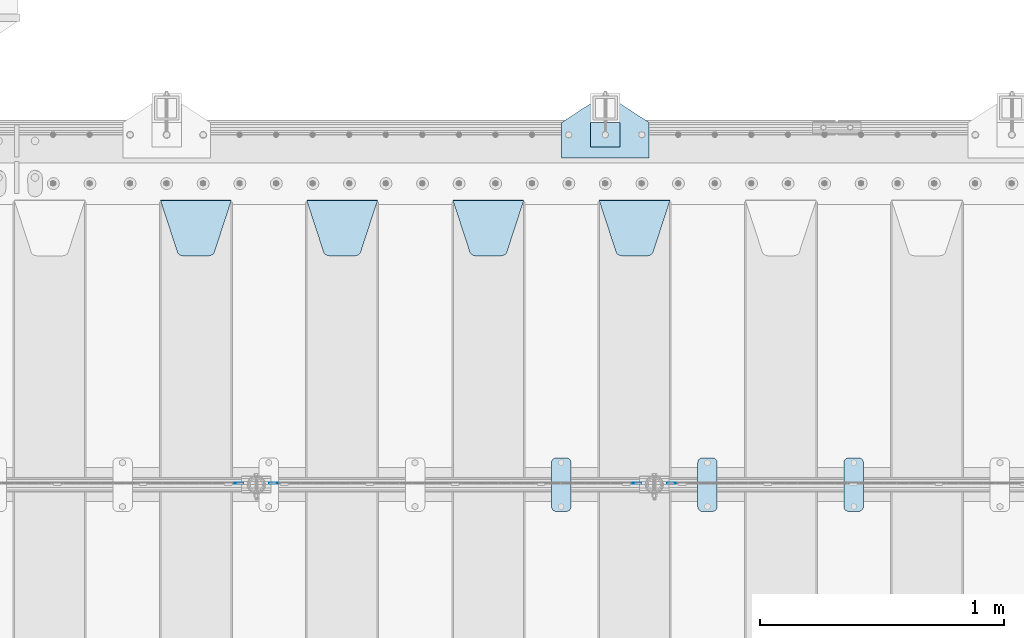
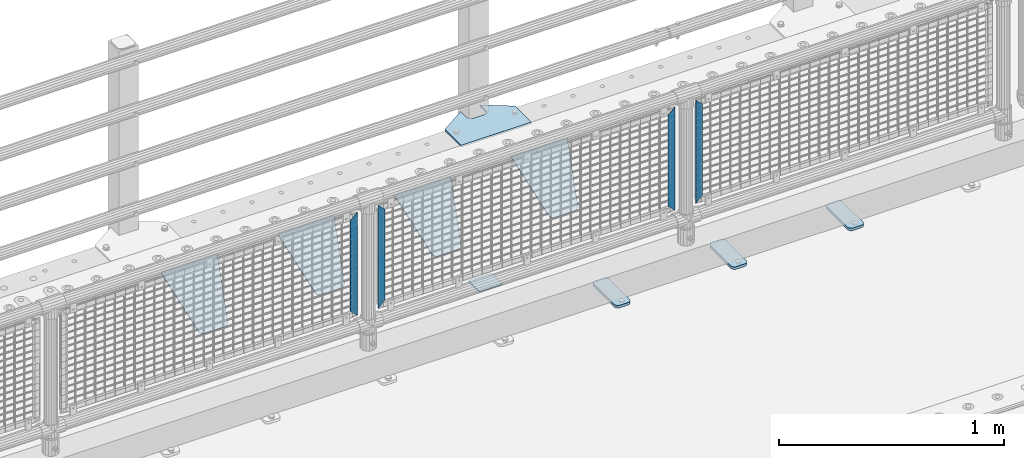
# One storey, part 249 of 270: 13 plates.
"""IFC2X3 building model written with IfcOpenShell, lengths in millimetres."""

from ifc_helpers import new_model, si_unit, frame, origin_with_axes, place, context, subcontext, project, spatial, faceted_brep, material, type_object, element, save


model = new_model("IFC2X3")

# Units and contexts
model_context = context("Model", 3, precision=1e-05, world=origin_with_axes())
body_context = subcontext(model_context, "Body", "Model", "MODEL_VIEW")
ifc_project = project(units=[si_unit("LENGTHUNIT", "METRE", prefix="MILLI"), si_unit("AREAUNIT", "SQUARE_METRE"), si_unit("VOLUMEUNIT", "CUBIC_METRE"), si_unit("MASSUNIT", "GRAM", prefix="KILO"), si_unit("TIMEUNIT", "SECOND"), si_unit("PLANEANGLEUNIT", "RADIAN"), si_unit("SOLIDANGLEUNIT", "STERADIAN"), si_unit("THERMODYNAMICTEMPERATUREUNIT", "DEGREE_CELSIUS"), si_unit("LUMINOUSINTENSITYUNIT", "LUMEN")], contexts=[model_context])

# Site, building, storey
site_placement = place(None, origin_with_axes())
site = spatial("IfcSite", under=ifc_project, at=site_placement, CompositionType="ELEMENT")
building_placement = place(site_placement, origin_with_axes())
building = spatial("IfcBuilding", under=site, at=building_placement, Name="Standard", CompositionType="ELEMENT")
storey_placement = place(building_placement, origin_with_axes())
storey = spatial("IfcBuildingStorey", under=building, at=storey_placement, Name="Undefined", CompositionType="ELEMENT", Elevation=0.0)

# Plates
ifc_material_1 = material(Name="STEEL/S355J2")
plate_type_1 = type_object("IfcPlateType", PredefinedType="NOTDEFINED")
plate_1_placement = place(storey_placement, frame((16570.0, -14995.0, 5.00000000004911), z_axis=(0.0, 1.0, 0.0), x_axis=(1.0, 0.0, 0.0)))
element("IfcPlate", 1, at=plate_1_placement, inside=storey, type_object=plate_type_1, material=ifc_material_1, context=body_context, shape_type="Brep", body=[
    faceted_brep([(0.0, -5.0, 0.0), (2.31396552408114e-06, -5.0, 145.0), (2.31396552408114e-06, 5.0, 145.0), (0.0, 5.0, 0.0), (130.0, -5.0, 230.0), (130.0, 5.0, 230.0), (130.0, -5.0, 180.0), (130.0, 5.0, 180.0), (130.48036798992, -5.0, 175.122741949597), (130.48036798992, 5.0, 175.122741949597), (131.903011687216, -5.0, 170.432914190873), (131.903011687216, 5.0, 170.432914190873), (134.213259692435, -5.0, 166.11074417451), (134.213259692435, 5.0, 166.11074417451), (137.322330470335, -5.0, 162.322330470337), (137.322330470335, 5.0, 162.322330470337), (141.110744174512, -5.0, 159.213259692437), (141.110744174512, 5.0, 159.213259692437), (145.432914190871, -5.0, 156.903011687218), (145.432914190871, 5.0, 156.903011687218), (150.122741949595, -5.0, 155.48036798992), (150.122741949595, 5.0, 155.48036798992), (155.0, -5.0, 155.0), (155.0, 5.0, 155.0), (205.0, -5.0, 155.0), (205.0, 5.0, 155.0), (209.877258050405, -5.0, 155.48036798992), (209.877258050405, 5.0, 155.48036798992), (214.567085809129, -5.0, 156.903011687218), (214.567085809129, 5.0, 156.903011687218), (218.889255825488, -5.0, 159.213259692437), (218.889255825488, 5.0, 159.213259692437), (222.677669529665, -5.0, 162.322330470337), (222.677669529665, 5.0, 162.322330470337), (225.786740307565, -5.0, 166.11074417451), (225.786740307565, 5.0, 166.11074417451), (228.096988312784, -5.0, 170.432914190873), (228.096988312784, 5.0, 170.432914190873), (229.51963201008, -5.0, 175.122741949597), (229.51963201008, 5.0, 175.122741949597), (230.0, -5.0, 180.0), (230.0, 5.0, 180.0), (230.0, -5.0, 230.0), (230.0, 5.0, 230.0), (360.0, -5.0, 145.0), (360.0, 5.0, 145.0), (360.0, -5.0, -7.27595761418343e-12), (360.0, 5.0, -7.27595761418343e-12)], [[[0, 1, 2, 3]], [[1, 4, 5, 2]], [[4, 6, 7, 5]], [[6, 8, 9, 7]], [[8, 10, 11, 9]], [[10, 12, 13, 11]], [[12, 14, 15, 13]], [[14, 16, 17, 15]], [[16, 18, 19, 17]], [[18, 20, 21, 19]], [[20, 22, 23, 21]], [[22, 24, 25, 23]], [[24, 26, 27, 25]], [[26, 28, 29, 27]], [[28, 30, 31, 29]], [[30, 32, 33, 31]], [[32, 34, 35, 33]], [[34, 36, 37, 35]], [[36, 38, 39, 37]], [[38, 40, 41, 39]], [[40, 42, 43, 41]], [[42, 44, 45, 43]], [[44, 46, 47, 45]], [[46, 0, 3, 47]], [[5, 7, 9, 11, 13, 15, 17, 19, 21, 23, 25, 27, 29, 31, 33, 35, 37, 39, 41, 43, 45, 47, 3, 2]], [[46, 44, 42, 40, 38, 36, 34, 32, 30, 28, 26, 24, 22, 20, 18, 16, 14, 12, 10, 8, 6, 4, 1, 0]]]),
])
plate_type_2 = type_object("IfcPlateType", PredefinedType="NOTDEFINED")
plate_2_placement = place(storey_placement, frame((16690.0000000001, -14949.9999999998, -857.500000000002), z_axis=(0.0, 1.0, 0.0), x_axis=(1.0, 0.0, 0.0)))
element("IfcPlate", 2, at=plate_2_placement, inside=storey, type_object=plate_type_2, material=ifc_material_1, context=body_context, shape_type="Brep", body=[
    faceted_brep([(0.0, -2.5, 0.0), (0.0, -2.5, 100.0), (0.0, 2.5, 100.0), (0.0, 2.5, 0.0), (120.0, -2.5, 100.0), (120.0, 2.5, 100.0), (120.0, -2.5, 0.0), (120.0, 2.5, 0.0)], [[[0, 1, 2, 3]], [[1, 4, 5, 2]], [[4, 6, 7, 5]], [[6, 0, 3, 7]], [[5, 7, 3, 2]], [[6, 4, 1, 0]]]),
])
plate_type_3 = type_object("IfcPlateType", PredefinedType="NOTDEFINED")
plate_3_placement = place(storey_placement, frame((17729.0, -16225.5, 21.0199999999977), z_axis=(1.0, 0.0, 0.0), x_axis=(0.0, -1.0, 0.0)))
element("IfcPlate", 3, at=plate_3_placement, inside=storey, type_object=plate_type_3, material=ifc_material_1, context=body_context, shape_type="Brep", body=[
    faceted_brep([(0.0, -7.0, 20.0), (0.0, -7.0, 60.0), (0.0, 7.0, 60.0), (0.0, 7.0, 20.0), (0.384294391937146, -7.0, 63.9018064403208), (0.384294391937146, 7.0, 63.9018064403208), (1.52240934977453, -7.0, 67.6536686473009), (1.52240934977453, 7.0, 67.6536686473009), (3.37060775395003, -7.0, 71.1114046603907), (3.37060775395003, 7.0, 71.1114046603907), (5.8578643762703, -7.0, 74.1421356237297), (5.8578643762703, 7.0, 74.1421356237297), (8.88859533960931, -7.0, 76.62939224605), (8.88859533960931, 7.0, 76.62939224605), (12.3463313526991, -7.0, 78.4775906502255), (12.3463313526991, 7.0, 78.4775906502255), (16.0981935596792, -7.0, 79.6157056080629), (16.0981935596792, 7.0, 79.6157056080629), (20.0, -7.0, 80.0), (20.0, 7.0, 80.0), (200.0, -7.0, 80.0), (200.0, 7.0, 80.0), (203.901806440321, -7.0, 79.6157056080629), (203.901806440321, 7.0, 79.6157056080629), (207.653668647301, -7.0, 78.4775906502255), (207.653668647301, 7.0, 78.4775906502255), (211.111404660391, -7.0, 76.62939224605), (211.111404660391, 7.0, 76.62939224605), (214.142135623733, -7.0, 74.1421356237297), (214.142135623733, 7.0, 74.1421356237297), (216.629392246054, -7.0, 71.1114046603907), (216.629392246054, 7.0, 71.1114046603907), (218.477590650225, -7.0, 67.6536686473009), (218.477590650225, 7.0, 67.6536686473009), (219.615705608063, -7.0, 63.9018064403208), (219.615705608063, 7.0, 63.9018064403208), (220.0, -7.0, 60.0), (220.0, 7.0, 60.0), (220.0, -7.0, 20.0), (220.0, 7.0, 20.0), (219.615705608063, -7.0, 16.0981935596792), (219.615705608063, 7.0, 16.0981935596792), (218.477590650225, -7.0, 12.3463313526991), (218.477590650225, 7.0, 12.3463313526991), (216.629392246054, -7.0, 8.88859533960931), (216.629392246054, 7.0, 8.88859533960931), (214.142135623733, -7.0, 5.8578643762703), (214.142135623733, 7.0, 5.8578643762703), (211.111404660391, -7.0, 3.37060775395003), (211.111404660391, 7.0, 3.37060775395003), (207.653668647301, -7.0, 1.52240934977453), (207.653668647301, 7.0, 1.52240934977453), (203.901806440321, -7.0, 0.384294391937146), (203.901806440321, 7.0, 0.384294391937146), (200.0, -7.0, 0.0), (200.0, 7.0, 0.0), (20.0, -7.0, 0.0), (20.0, 7.0, 0.0), (16.0981935596792, -7.0, 0.384294391937146), (16.0981935596792, 7.0, 0.384294391937146), (12.3463313526991, -7.0, 1.52240934977453), (12.3463313526991, 7.0, 1.52240934977453), (8.88859533960931, -7.0, 3.37060775395003), (8.88859533960931, 7.0, 3.37060775395003), (5.8578643762703, -7.0, 5.8578643762703), (5.8578643762703, 7.0, 5.8578643762703), (3.37060775395003, -7.0, 8.88859533960931), (3.37060775395003, 7.0, 8.88859533960931), (1.52240934977453, -7.0, 12.3463313526991), (1.52240934977453, 7.0, 12.3463313526991), (0.384294391937146, -7.0, 16.0981935596792), (0.384294391937146, 7.0, 16.0981935596792)], [[[0, 1, 2, 3]], [[1, 4, 5, 2]], [[4, 6, 7, 5]], [[6, 8, 9, 7]], [[8, 10, 11, 9]], [[10, 12, 13, 11]], [[12, 14, 15, 13]], [[14, 16, 17, 15]], [[16, 18, 19, 17]], [[18, 20, 21, 19]], [[20, 22, 23, 21]], [[22, 24, 25, 23]], [[24, 26, 27, 25]], [[26, 28, 29, 27]], [[28, 30, 31, 29]], [[30, 32, 33, 31]], [[32, 34, 35, 33]], [[34, 36, 37, 35]], [[36, 38, 39, 37]], [[38, 40, 41, 39]], [[40, 42, 43, 41]], [[42, 44, 45, 43]], [[44, 46, 47, 45]], [[46, 48, 49, 47]], [[48, 50, 51, 49]], [[50, 52, 53, 51]], [[52, 54, 55, 53]], [[54, 56, 57, 55]], [[56, 58, 59, 57]], [[58, 60, 61, 59]], [[60, 62, 63, 61]], [[62, 64, 65, 63]], [[64, 66, 67, 65]], [[66, 68, 69, 67]], [[68, 70, 71, 69]], [[70, 0, 3, 71]], [[5, 7, 9, 11, 13, 15, 17, 19, 21, 23, 25, 27, 29, 31, 33, 35, 37, 39, 41, 43, 45, 47, 49, 51, 53, 55, 57, 59, 61, 63, 65, 67, 69, 71, 3, 2]], [[70, 68, 66, 64, 62, 60, 58, 56, 54, 52, 50, 48, 46, 44, 42, 40, 38, 36, 34, 32, 30, 28, 26, 24, 22, 20, 18, 16, 14, 12, 10, 8, 6, 4, 1, 0]]]),
])
plate_4_placement = place(storey_placement, frame((17129.0, -16225.5, 21.0199999999977), z_axis=(1.0, 0.0, 0.0), x_axis=(0.0, -1.0, 0.0)))
element("IfcPlate", 4, at=plate_4_placement, inside=storey, type_object=plate_type_3, material=ifc_material_1, context=body_context, shape_type="Brep", body=[
    faceted_brep([(0.0, -7.0, 20.0), (0.0, -7.0, 60.0), (0.0, 7.0, 60.0), (0.0, 7.0, 20.0), (0.384294391937146, -7.0, 63.9018064403208), (0.384294391937146, 7.0, 63.9018064403208), (1.52240934977453, -7.0, 67.6536686473009), (1.52240934977453, 7.0, 67.6536686473009), (3.37060775395003, -7.0, 71.1114046603907), (3.37060775395003, 7.0, 71.1114046603907), (5.8578643762703, -7.0, 74.1421356237297), (5.8578643762703, 7.0, 74.1421356237297), (8.88859533960931, -7.0, 76.62939224605), (8.88859533960931, 7.0, 76.62939224605), (12.3463313526991, -7.0, 78.4775906502255), (12.3463313526991, 7.0, 78.4775906502255), (16.0981935596792, -7.0, 79.6157056080629), (16.0981935596792, 7.0, 79.6157056080629), (20.0, -7.0, 80.0), (20.0, 7.0, 80.0), (200.0, -7.0, 80.0), (200.0, 7.0, 80.0), (203.901806440321, -7.0, 79.6157056080629), (203.901806440321, 7.0, 79.6157056080629), (207.653668647301, -7.0, 78.4775906502255), (207.653668647301, 7.0, 78.4775906502255), (211.111404660391, -7.0, 76.62939224605), (211.111404660391, 7.0, 76.62939224605), (214.142135623733, -7.0, 74.1421356237297), (214.142135623733, 7.0, 74.1421356237297), (216.629392246054, -7.0, 71.1114046603907), (216.629392246054, 7.0, 71.1114046603907), (218.477590650225, -7.0, 67.6536686473009), (218.477590650225, 7.0, 67.6536686473009), (219.615705608063, -7.0, 63.9018064403208), (219.615705608063, 7.0, 63.9018064403208), (220.0, -7.0, 60.0), (220.0, 7.0, 60.0), (220.0, -7.0, 20.0), (220.0, 7.0, 20.0), (219.615705608063, -7.0, 16.0981935596792), (219.615705608063, 7.0, 16.0981935596792), (218.477590650225, -7.0, 12.3463313526991), (218.477590650225, 7.0, 12.3463313526991), (216.629392246054, -7.0, 8.88859533960931), (216.629392246054, 7.0, 8.88859533960931), (214.142135623733, -7.0, 5.8578643762703), (214.142135623733, 7.0, 5.8578643762703), (211.111404660391, -7.0, 3.37060775395003), (211.111404660391, 7.0, 3.37060775395003), (207.653668647301, -7.0, 1.52240934977453), (207.653668647301, 7.0, 1.52240934977453), (203.901806440321, -7.0, 0.384294391937146), (203.901806440321, 7.0, 0.384294391937146), (200.0, -7.0, 0.0), (200.0, 7.0, 0.0), (20.0, -7.0, 0.0), (20.0, 7.0, 0.0), (16.0981935596792, -7.0, 0.384294391937146), (16.0981935596792, 7.0, 0.384294391937146), (12.3463313526991, -7.0, 1.52240934977453), (12.3463313526991, 7.0, 1.52240934977453), (8.88859533960931, -7.0, 3.37060775395003), (8.88859533960931, 7.0, 3.37060775395003), (5.8578643762703, -7.0, 5.8578643762703), (5.8578643762703, 7.0, 5.8578643762703), (3.37060775395003, -7.0, 8.88859533960931), (3.37060775395003, 7.0, 8.88859533960931), (1.52240934977453, -7.0, 12.3463313526991), (1.52240934977453, 7.0, 12.3463313526991), (0.384294391937146, -7.0, 16.0981935596792), (0.384294391937146, 7.0, 16.0981935596792)], [[[0, 1, 2, 3]], [[1, 4, 5, 2]], [[4, 6, 7, 5]], [[6, 8, 9, 7]], [[8, 10, 11, 9]], [[10, 12, 13, 11]], [[12, 14, 15, 13]], [[14, 16, 17, 15]], [[16, 18, 19, 17]], [[18, 20, 21, 19]], [[20, 22, 23, 21]], [[22, 24, 25, 23]], [[24, 26, 27, 25]], [[26, 28, 29, 27]], [[28, 30, 31, 29]], [[30, 32, 33, 31]], [[32, 34, 35, 33]], [[34, 36, 37, 35]], [[36, 38, 39, 37]], [[38, 40, 41, 39]], [[40, 42, 43, 41]], [[42, 44, 45, 43]], [[44, 46, 47, 45]], [[46, 48, 49, 47]], [[48, 50, 51, 49]], [[50, 52, 53, 51]], [[52, 54, 55, 53]], [[54, 56, 57, 55]], [[56, 58, 59, 57]], [[58, 60, 61, 59]], [[60, 62, 63, 61]], [[62, 64, 65, 63]], [[64, 66, 67, 65]], [[66, 68, 69, 67]], [[68, 70, 71, 69]], [[70, 0, 3, 71]], [[5, 7, 9, 11, 13, 15, 17, 19, 21, 23, 25, 27, 29, 31, 33, 35, 37, 39, 41, 43, 45, 47, 49, 51, 53, 55, 57, 59, 61, 63, 65, 67, 69, 71, 3, 2]], [[70, 68, 66, 64, 62, 60, 58, 56, 54, 52, 50, 48, 46, 44, 42, 40, 38, 36, 34, 32, 30, 28, 26, 24, 22, 20, 18, 16, 14, 12, 10, 8, 6, 4, 1, 0]]]),
])
plate_5_placement = place(storey_placement, frame((16529.0, -16225.5, 21.0199999999977), z_axis=(1.0, 0.0, 0.0), x_axis=(0.0, -1.0, 0.0)))
element("IfcPlate", 5, at=plate_5_placement, inside=storey, type_object=plate_type_3, material=ifc_material_1, context=body_context, shape_type="Brep", body=[
    faceted_brep([(0.0, -7.0, 20.0), (0.0, -7.0, 60.0), (0.0, 7.0, 60.0), (0.0, 7.0, 20.0), (0.384294391937146, -7.0, 63.9018064403208), (0.384294391937146, 7.0, 63.9018064403208), (1.52240934977453, -7.0, 67.6536686473009), (1.52240934977453, 7.0, 67.6536686473009), (3.37060775395003, -7.0, 71.1114046603907), (3.37060775395003, 7.0, 71.1114046603907), (5.8578643762703, -7.0, 74.1421356237297), (5.8578643762703, 7.0, 74.1421356237297), (8.88859533960931, -7.0, 76.62939224605), (8.88859533960931, 7.0, 76.62939224605), (12.3463313526991, -7.0, 78.4775906502255), (12.3463313526991, 7.0, 78.4775906502255), (16.0981935596792, -7.0, 79.6157056080629), (16.0981935596792, 7.0, 79.6157056080629), (20.0, -7.0, 80.0), (20.0, 7.0, 80.0), (200.0, -7.0, 80.0), (200.0, 7.0, 80.0), (203.901806440321, -7.0, 79.6157056080629), (203.901806440321, 7.0, 79.6157056080629), (207.653668647301, -7.0, 78.4775906502255), (207.653668647301, 7.0, 78.4775906502255), (211.111404660391, -7.0, 76.62939224605), (211.111404660391, 7.0, 76.62939224605), (214.142135623733, -7.0, 74.1421356237297), (214.142135623733, 7.0, 74.1421356237297), (216.629392246054, -7.0, 71.1114046603907), (216.629392246054, 7.0, 71.1114046603907), (218.477590650225, -7.0, 67.6536686473009), (218.477590650225, 7.0, 67.6536686473009), (219.615705608063, -7.0, 63.9018064403208), (219.615705608063, 7.0, 63.9018064403208), (220.0, -7.0, 60.0), (220.0, 7.0, 60.0), (220.0, -7.0, 20.0), (220.0, 7.0, 20.0), (219.615705608063, -7.0, 16.0981935596792), (219.615705608063, 7.0, 16.0981935596792), (218.477590650225, -7.0, 12.3463313526991), (218.477590650225, 7.0, 12.3463313526991), (216.629392246054, -7.0, 8.88859533960931), (216.629392246054, 7.0, 8.88859533960931), (214.142135623733, -7.0, 5.8578643762703), (214.142135623733, 7.0, 5.8578643762703), (211.111404660391, -7.0, 3.37060775395003), (211.111404660391, 7.0, 3.37060775395003), (207.653668647301, -7.0, 1.52240934977453), (207.653668647301, 7.0, 1.52240934977453), (203.901806440321, -7.0, 0.384294391937146), (203.901806440321, 7.0, 0.384294391937146), (200.0, -7.0, 0.0), (200.0, 7.0, 0.0), (20.0, -7.0, 0.0), (20.0, 7.0, 0.0), (16.0981935596792, -7.0, 0.384294391937146), (16.0981935596792, 7.0, 0.384294391937146), (12.3463313526991, -7.0, 1.52240934977453), (12.3463313526991, 7.0, 1.52240934977453), (8.88859533960931, -7.0, 3.37060775395003), (8.88859533960931, 7.0, 3.37060775395003), (5.8578643762703, -7.0, 5.8578643762703), (5.8578643762703, 7.0, 5.8578643762703), (3.37060775395003, -7.0, 8.88859533960931), (3.37060775395003, 7.0, 8.88859533960931), (1.52240934977453, -7.0, 12.3463313526991), (1.52240934977453, 7.0, 12.3463313526991), (0.384294391937146, -7.0, 16.0981935596792), (0.384294391937146, 7.0, 16.0981935596792)], [[[0, 1, 2, 3]], [[1, 4, 5, 2]], [[4, 6, 7, 5]], [[6, 8, 9, 7]], [[8, 10, 11, 9]], [[10, 12, 13, 11]], [[12, 14, 15, 13]], [[14, 16, 17, 15]], [[16, 18, 19, 17]], [[18, 20, 21, 19]], [[20, 22, 23, 21]], [[22, 24, 25, 23]], [[24, 26, 27, 25]], [[26, 28, 29, 27]], [[28, 30, 31, 29]], [[30, 32, 33, 31]], [[32, 34, 35, 33]], [[34, 36, 37, 35]], [[36, 38, 39, 37]], [[38, 40, 41, 39]], [[40, 42, 43, 41]], [[42, 44, 45, 43]], [[44, 46, 47, 45]], [[46, 48, 49, 47]], [[48, 50, 51, 49]], [[50, 52, 53, 51]], [[52, 54, 55, 53]], [[54, 56, 57, 55]], [[56, 58, 59, 57]], [[58, 60, 61, 59]], [[60, 62, 63, 61]], [[62, 64, 65, 63]], [[64, 66, 67, 65]], [[66, 68, 69, 67]], [[68, 70, 71, 69]], [[70, 0, 3, 71]], [[5, 7, 9, 11, 13, 15, 17, 19, 21, 23, 25, 27, 29, 31, 33, 35, 37, 39, 41, 43, 45, 47, 49, 51, 53, 55, 57, 59, 61, 63, 65, 67, 69, 71, 3, 2]], [[70, 68, 66, 64, 62, 60, 58, 56, 54, 52, 50, 48, 46, 44, 42, 40, 38, 36, 34, 32, 30, 28, 26, 24, 22, 20, 18, 16, 14, 12, 10, 8, 6, 4, 1, 0]]]),
])
ifc_material_2 = material(Name="STEEL/S355N")
plate_type_4 = type_object("IfcPlateType", PredefinedType="NOTDEFINED")
plate_6_placement = place(storey_placement, frame((16725.0, -15168.2322330441, -1.76776695296576), z_axis=(0.0, -0.707106781186548, -0.707106781186547), x_axis=(1.0, 0.0, 0.0)))
element("IfcPlate", 6, at=plate_6_placement, inside=storey, type_object=plate_type_4, material=ifc_material_2, context=body_context, shape_type="Brep", body=[
    faceted_brep([(0.0, -2.5, 0.0), (69.345504679477, -2.5, 300.171731424831), (69.345504679477, 2.5, 300.171731424831), (0.0, 2.5, 0.0), (70.9274061199576, -2.5, 304.8974424154), (70.9274061199576, 2.5, 304.8974424154), (73.3818627772307, -2.49999999999818, 309.234538108527), (73.3818627772307, 2.50000000000182, 309.234538108527), (76.6187032999551, -2.5, 313.023683126103), (76.6187032999551, 2.5, 313.023683126103), (80.5190132704993, -2.5, 316.125672595372), (80.5190132704993, 2.50000000000182, 316.125672595372), (84.9395038596849, -2.49999999999818, 318.426546230476), (84.9395038596849, 2.5, 318.426546230476), (89.7177759439219, -2.49999999999818, 319.841774983275), (89.7177759439219, 2.50000000000182, 319.841774983275), (94.678286292652, -2.5, 320.319366455078), (94.678286292652, 2.5, 320.319366455078), (195.321713707348, -2.5, 320.319366455078), (195.321713707348, 2.5, 320.319366455078), (200.282224056078, -2.49999999999818, 319.841774983275), (200.282224056078, 2.50000000000182, 319.841774983275), (205.060496140315, -2.5, 318.426546230476), (205.060496140315, 2.5, 318.426546230476), (209.480986729501, -2.5, 316.12567259537), (209.480986729501, 2.50000000000182, 316.12567259537), (213.381296700045, -2.5, 313.023683126103), (213.381296700045, 2.5, 313.023683126103), (216.618137222769, -2.49999999999818, 309.234538108525), (216.618137222769, 2.50000000000182, 309.234538108527), (219.072593880042, -2.49999999999818, 304.897442415398), (219.072593880042, 2.50000000000182, 304.897442415397), (220.654495320523, -2.5, 300.171731424831), (220.654495320523, 2.5, 300.171731424831), (290.0, -2.49999999999818, 0.0), (290.0, 2.5, 0.0)], [[[0, 1, 2, 3]], [[1, 4, 5, 2]], [[4, 6, 7, 5]], [[6, 8, 9, 7]], [[8, 10, 11, 9]], [[10, 12, 13, 11]], [[12, 14, 15, 13]], [[14, 16, 17, 15]], [[16, 18, 19, 17]], [[18, 20, 21, 19]], [[20, 22, 23, 21]], [[22, 24, 25, 23]], [[24, 26, 27, 25]], [[26, 28, 29, 27]], [[28, 30, 31, 29]], [[30, 32, 33, 31]], [[32, 34, 35, 33]], [[34, 0, 3, 35]], [[5, 7, 9, 11, 13, 15, 17, 19, 21, 23, 25, 27, 29, 31, 33, 35, 3, 2]], [[34, 32, 30, 28, 26, 24, 22, 20, 18, 16, 14, 12, 10, 8, 6, 4, 1, 0]]]),
])
plate_7_placement = place(storey_placement, frame((16125.0, -15168.2322330441, -1.76776695296576), z_axis=(0.0, -0.707106781186548, -0.707106781186547), x_axis=(1.0, 0.0, 0.0)))
element("IfcPlate", 7, at=plate_7_placement, inside=storey, type_object=plate_type_4, material=ifc_material_2, context=body_context, shape_type="Brep", body=[
    faceted_brep([(0.0, -2.5, 0.0), (69.345504679477, -2.5, 300.171731424831), (69.345504679477, 2.5, 300.171731424831), (0.0, 2.5, 0.0), (70.9274061199576, -2.5, 304.8974424154), (70.9274061199576, 2.5, 304.8974424154), (73.3818627772307, -2.49999999999818, 309.234538108527), (73.3818627772307, 2.50000000000182, 309.234538108527), (76.6187032999551, -2.5, 313.023683126103), (76.6187032999551, 2.5, 313.023683126103), (80.5190132704993, -2.5, 316.125672595372), (80.5190132704993, 2.50000000000182, 316.125672595372), (84.9395038596849, -2.49999999999818, 318.426546230476), (84.9395038596849, 2.5, 318.426546230476), (89.7177759439219, -2.49999999999818, 319.841774983275), (89.7177759439219, 2.50000000000182, 319.841774983275), (94.678286292652, -2.5, 320.319366455078), (94.678286292652, 2.5, 320.319366455078), (195.321713707348, -2.5, 320.319366455078), (195.321713707348, 2.5, 320.319366455078), (200.282224056078, -2.49999999999818, 319.841774983275), (200.282224056078, 2.50000000000182, 319.841774983275), (205.060496140315, -2.5, 318.426546230476), (205.060496140315, 2.5, 318.426546230476), (209.480986729501, -2.5, 316.12567259537), (209.480986729501, 2.50000000000182, 316.12567259537), (213.381296700045, -2.5, 313.023683126103), (213.381296700045, 2.5, 313.023683126103), (216.618137222769, -2.49999999999818, 309.234538108525), (216.618137222769, 2.50000000000182, 309.234538108527), (219.072593880042, -2.49999999999818, 304.897442415398), (219.072593880042, 2.50000000000182, 304.897442415397), (220.654495320523, -2.5, 300.171731424831), (220.654495320523, 2.5, 300.171731424831), (290.0, -2.49999999999818, 0.0), (290.0, 2.5, 0.0)], [[[0, 1, 2, 3]], [[1, 4, 5, 2]], [[4, 6, 7, 5]], [[6, 8, 9, 7]], [[8, 10, 11, 9]], [[10, 12, 13, 11]], [[12, 14, 15, 13]], [[14, 16, 17, 15]], [[16, 18, 19, 17]], [[18, 20, 21, 19]], [[20, 22, 23, 21]], [[22, 24, 25, 23]], [[24, 26, 27, 25]], [[26, 28, 29, 27]], [[28, 30, 31, 29]], [[30, 32, 33, 31]], [[32, 34, 35, 33]], [[34, 0, 3, 35]], [[5, 7, 9, 11, 13, 15, 17, 19, 21, 23, 25, 27, 29, 31, 33, 35, 3, 2]], [[34, 32, 30, 28, 26, 24, 22, 20, 18, 16, 14, 12, 10, 8, 6, 4, 1, 0]]]),
])
plate_8_placement = place(storey_placement, frame((15525.0, -15168.2322330441, -1.76776695296576), z_axis=(0.0, -0.707106781186548, -0.707106781186547), x_axis=(1.0, 0.0, 0.0)))
element("IfcPlate", 8, at=plate_8_placement, inside=storey, type_object=plate_type_4, material=ifc_material_2, context=body_context, shape_type="Brep", body=[
    faceted_brep([(0.0, -2.5, 0.0), (69.345504679477, -2.5, 300.171731424831), (69.345504679477, 2.5, 300.171731424831), (0.0, 2.5, 0.0), (70.9274061199576, -2.5, 304.8974424154), (70.9274061199576, 2.5, 304.8974424154), (73.3818627772307, -2.49999999999818, 309.234538108527), (73.3818627772307, 2.50000000000182, 309.234538108527), (76.6187032999551, -2.5, 313.023683126103), (76.6187032999551, 2.5, 313.023683126103), (80.5190132704993, -2.5, 316.125672595372), (80.5190132704993, 2.50000000000182, 316.125672595372), (84.9395038596849, -2.49999999999818, 318.426546230476), (84.9395038596849, 2.5, 318.426546230476), (89.7177759439219, -2.49999999999818, 319.841774983275), (89.7177759439219, 2.50000000000182, 319.841774983275), (94.678286292652, -2.5, 320.319366455078), (94.678286292652, 2.5, 320.319366455078), (195.321713707348, -2.5, 320.319366455078), (195.321713707348, 2.5, 320.319366455078), (200.282224056078, -2.49999999999818, 319.841774983275), (200.282224056078, 2.50000000000182, 319.841774983275), (205.060496140315, -2.5, 318.426546230476), (205.060496140315, 2.5, 318.426546230476), (209.480986729501, -2.5, 316.12567259537), (209.480986729501, 2.50000000000182, 316.12567259537), (213.381296700045, -2.5, 313.023683126103), (213.381296700045, 2.5, 313.023683126103), (216.618137222769, -2.49999999999818, 309.234538108525), (216.618137222769, 2.50000000000182, 309.234538108527), (219.072593880042, -2.49999999999818, 304.897442415398), (219.072593880042, 2.50000000000182, 304.897442415397), (220.654495320523, -2.5, 300.171731424831), (220.654495320523, 2.5, 300.171731424831), (290.0, -2.49999999999818, 0.0), (290.0, 2.5, 0.0)], [[[0, 1, 2, 3]], [[1, 4, 5, 2]], [[4, 6, 7, 5]], [[6, 8, 9, 7]], [[8, 10, 11, 9]], [[10, 12, 13, 11]], [[12, 14, 15, 13]], [[14, 16, 17, 15]], [[16, 18, 19, 17]], [[18, 20, 21, 19]], [[20, 22, 23, 21]], [[22, 24, 25, 23]], [[24, 26, 27, 25]], [[26, 28, 29, 27]], [[28, 30, 31, 29]], [[30, 32, 33, 31]], [[32, 34, 35, 33]], [[34, 0, 3, 35]], [[5, 7, 9, 11, 13, 15, 17, 19, 21, 23, 25, 27, 29, 31, 33, 35, 3, 2]], [[34, 32, 30, 28, 26, 24, 22, 20, 18, 16, 14, 12, 10, 8, 6, 4, 1, 0]]]),
])
plate_9_placement = place(storey_placement, frame((14925.0, -15168.2322330441, -1.76776695296576), z_axis=(0.0, -0.707106781186548, -0.707106781186547), x_axis=(1.0, 0.0, 0.0)))
element("IfcPlate", 9, at=plate_9_placement, inside=storey, type_object=plate_type_4, material=ifc_material_2, context=body_context, shape_type="Brep", body=[
    faceted_brep([(0.0, -2.5, 0.0), (69.345504679477, -2.5, 300.171731424831), (69.345504679477, 2.5, 300.171731424831), (0.0, 2.5, 0.0), (70.9274061199576, -2.5, 304.8974424154), (70.9274061199576, 2.5, 304.8974424154), (73.3818627772307, -2.49999999999818, 309.234538108527), (73.3818627772307, 2.50000000000182, 309.234538108527), (76.6187032999551, -2.5, 313.023683126103), (76.6187032999551, 2.5, 313.023683126103), (80.5190132704993, -2.5, 316.125672595372), (80.5190132704993, 2.50000000000182, 316.125672595372), (84.9395038596849, -2.49999999999818, 318.426546230476), (84.9395038596849, 2.5, 318.426546230476), (89.7177759439219, -2.49999999999818, 319.841774983275), (89.7177759439219, 2.50000000000182, 319.841774983275), (94.678286292652, -2.5, 320.319366455078), (94.678286292652, 2.5, 320.319366455078), (195.321713707348, -2.5, 320.319366455078), (195.321713707348, 2.5, 320.319366455078), (200.282224056078, -2.49999999999818, 319.841774983275), (200.282224056078, 2.50000000000182, 319.841774983275), (205.060496140315, -2.5, 318.426546230476), (205.060496140315, 2.5, 318.426546230476), (209.480986729501, -2.5, 316.12567259537), (209.480986729501, 2.50000000000182, 316.12567259537), (213.381296700045, -2.5, 313.023683126103), (213.381296700045, 2.5, 313.023683126103), (216.618137222769, -2.49999999999818, 309.234538108525), (216.618137222769, 2.50000000000182, 309.234538108527), (219.072593880042, -2.49999999999818, 304.897442415398), (219.072593880042, 2.50000000000182, 304.897442415397), (220.654495320523, -2.5, 300.171731424831), (220.654495320523, 2.5, 300.171731424831), (290.0, -2.49999999999818, 0.0), (290.0, 2.5, 0.0)], [[[0, 1, 2, 3]], [[1, 4, 5, 2]], [[4, 6, 7, 5]], [[6, 8, 9, 7]], [[8, 10, 11, 9]], [[10, 12, 13, 11]], [[12, 14, 15, 13]], [[14, 16, 17, 15]], [[16, 18, 19, 17]], [[18, 20, 21, 19]], [[20, 22, 23, 21]], [[22, 24, 25, 23]], [[24, 26, 27, 25]], [[26, 28, 29, 27]], [[28, 30, 31, 29]], [[30, 32, 33, 31]], [[32, 34, 35, 33]], [[34, 0, 3, 35]], [[5, 7, 9, 11, 13, 15, 17, 19, 21, 23, 25, 27, 29, 31, 33, 35, 3, 2]], [[34, 32, 30, 28, 26, 24, 22, 20, 18, 16, 14, 12, 10, 8, 6, 4, 1, 0]]]),
])
ifc_material_3 = material(Name="Misc_Undefined")
plate_type_5 = type_object("IfcPlateType", PredefinedType="NOTDEFINED")
for number, where, z_axis, x_axis in (
    (10, (17039.509713541, -16329.5, 879.519963133601), (-0.707008801899319, 0.0, -0.707204746899291), (-0.707204746899302, 0.0, 0.707008801899308)),
    (11, (15406.509713541, -16329.5, 879.519963133601), (-0.707008801899319, 0.0, -0.707204746899291), (-0.707204746899302, 0.0, 0.707008801899308)),
):
    element("IfcPlate", number, at=place(storey_placement, frame(where, z_axis=z_axis, x_axis=x_axis)), inside=storey, type_object=plate_type_5, material=ifc_material_3, context=body_context, shape_type="Brep", body=[
        faceted_brep([(0.0, -1.5, 0.0), (-348.552185058599, -1.5, 348.655029296877), (-348.552185058599, 1.5, 348.655029296877), (0.0, 1.5, 0.0), (-348.544891357427, -1.5, 398.152496337894), (-348.544891357427, 1.5, 398.152496337894), (49.50439453125, -1.5, 8.00355337560177e-11), (49.50439453125, 1.5, 8.00355337560177e-11)], [[[0, 1, 2, 3]], [[1, 4, 5, 2]], [[4, 6, 7, 5]], [[6, 0, 3, 7]], [[5, 7, 3, 2]], [[6, 4, 1, 0]]]),
    ])
for number, where, z_axis, x_axis in (
    (12, (16862.4996874836, -16329.5, 879.52), (0.707103624179499, 0.0, -0.707109938179501), (0.707109938179513, 0.0, 0.707103624179487)),
    (13, (15229.4996874836, -16329.5, 879.52), (0.707103624179499, 0.0, -0.707109938179501), (0.707109938179513, 0.0, 0.707103624179487)),
):
    element("IfcPlate", number, at=place(storey_placement, frame(where, z_axis=z_axis, x_axis=x_axis)), inside=storey, type_object=plate_type_5, material=ifc_material_3, context=body_context, shape_type="Brep", body=[
        faceted_brep([(0.0, -1.5, 0.0), (-348.605163574224, -1.5, 348.602081298828), (-348.605163574224, 1.5, 348.602081298828), (0.0, 1.5, 0.0), (-348.605163574226, -1.5, 398.099334716795), (-348.605163574226, 1.5, 398.099334716795), (49.4976959228497, -1.5, -7.27595761418343e-12), (49.4976959228497, 1.5, -7.27595761418343e-12)], [[[0, 1, 2, 3]], [[1, 4, 5, 2]], [[4, 6, 7, 5]], [[6, 0, 3, 7]], [[5, 7, 3, 2]], [[6, 4, 1, 0]]]),
    ])

save(model, "model.ifc")
